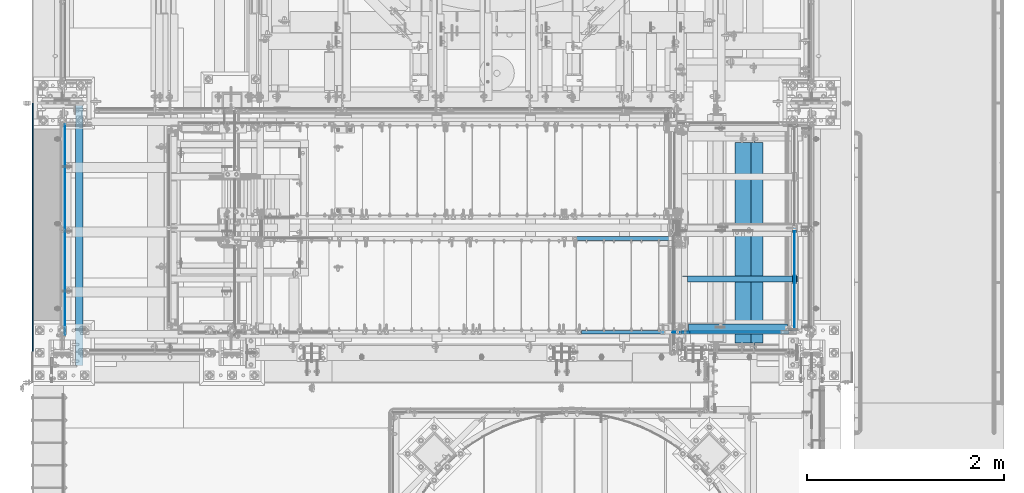
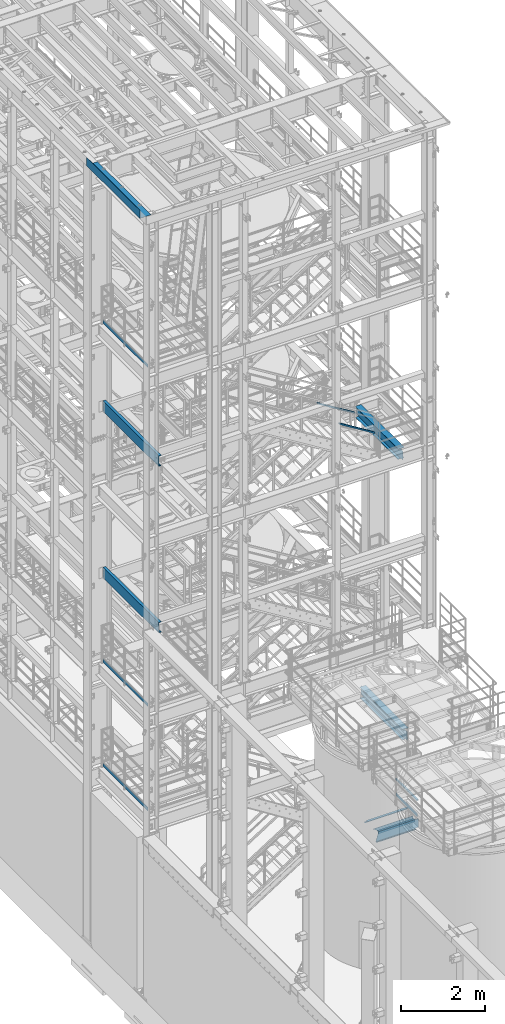
# One storey, part 951 of 1876: 14 beams, 2 members, 14 elements without a shape of their own.
"""IFC2X3 building model written with IfcOpenShell, lengths in millimetres."""

from ifc_helpers import new_model, si_unit, frame, origin_with_axes, place, context, subcontext, project, spatial, faceted_brep, material, type_object, element, aggregate, save


model = new_model("IFC2X3")

# Units and contexts
model_context = context("Model", 3, precision=1e-05, world=origin_with_axes())
body_context = subcontext(model_context, "Body", "Model", "MODEL_VIEW")
ifc_project = project(units=[si_unit("LENGTHUNIT", "METRE", prefix="MILLI"), si_unit("AREAUNIT", "SQUARE_METRE"), si_unit("VOLUMEUNIT", "CUBIC_METRE"), si_unit("MASSUNIT", "GRAM", prefix="KILO"), si_unit("TIMEUNIT", "SECOND"), si_unit("PLANEANGLEUNIT", "RADIAN"), si_unit("SOLIDANGLEUNIT", "STERADIAN"), si_unit("THERMODYNAMICTEMPERATUREUNIT", "DEGREE_CELSIUS"), si_unit("LUMINOUSINTENSITYUNIT", "LUMEN")], contexts=[model_context])

# Site, building, storey
site_placement = place(None, origin_with_axes())
site = spatial("IfcSite", under=ifc_project, at=site_placement, CompositionType="ELEMENT")
building_placement = place(site_placement, origin_with_axes())
building = spatial("IfcBuilding", under=site, at=building_placement, Name="Undefined", CompositionType="ELEMENT")
storey_placement = place(building_placement, origin_with_axes())
storey = spatial("IfcBuildingStorey", under=building, at=storey_placement, Name="Undefined", CompositionType="ELEMENT", Elevation=0.0)

# Assembly, beam
assembly_1_placement = place(storey_placement, origin_with_axes())
assembly_1 = element("IfcElementAssembly", 1, at=assembly_1_placement, inside=storey, Name="STRINGER", AssemblyPlace="NOTDEFINED", PredefinedType="RIGID_FRAME")
ifc_material_1 = material(Name="STEEL/A36")
beam_type_1 = type_object("IfcBeamType", Name="L2-1/2X2-1/2X1/4", PredefinedType="NOTDEFINED")
beam_1_placement = place(assembly_1_placement, frame((6299.20000038161, -6362.70000114059, 2266.27941853452), z_axis=(0.0, -1.0, 0.0), x_axis=(1.0, 0.0, 0.0)))
beam_1 = element("IfcBeam", 2, at=beam_1_placement, type_object=beam_type_1, material=ifc_material_1, Name="STRINGER", ObjectType="L2-1/2X2-1/2X1/4", context=body_context, shape_type="Brep", body=[
    faceted_brep([(1177.92499923677, 25.4000000000001, -25.3999999999996), (1177.92499923677, 25.4000000000001, 31.75), (58.737000000001, 25.4000000000001, 31.75), (58.737000000001, 25.4000000000001, -25.3999999999996), (1177.92499923677, 31.75, 31.75), (58.737000000001, 31.75, 31.75), (46.0370001907359, 6.34999909337057, -25.3999999999996), (46.0370001907359, 6.34999909337057, -31.75), (6.34999514770607, 6.34999909337057, -31.75), (6.34999514770607, 6.34999909337057, -25.3999999999996), (50.8970797087813, 7.31672901595857, -25.3999999999996), (50.8970797087813, 7.31672901595857, -31.75), (55.017256176935, 10.0697429164366, -25.3999999999996), (55.017256176935, 10.0697429164366, -31.75), (57.7702700774134, 14.1899193845902, -25.3999999999996), (57.7702700774134, 14.1899193845902, -31.75), (58.737000000001, 19.0499989026357, -25.3999999999996), (58.737000000001, 19.0499989026357, -31.75), (58.737000000001, 31.75, -31.75), (1177.92499923677, 31.75, -31.75), (1177.92499923677, -31.75, -25.3999999999996), (1177.92499923677, -31.75, -31.75), (6.34999999999854, -31.75, -25.3999999999996), (6.34999999999854, -31.75, -31.75), (6.34999514770607, -19.0499986178111, -31.75), (6.34999514770607, -19.0499986178111, -25.3999999999996)], [[[0, 1, 2, 3]], [[1, 4, 5, 2]], [[6, 7, 8, 9]], [[10, 11, 7, 6]], [[12, 13, 11, 10]], [[14, 15, 13, 12]], [[16, 17, 15, 14]], [[2, 5, 18, 17, 16, 3]], [[4, 19, 18, 5]], [[1, 0, 20, 21, 19, 4]], [[21, 20, 22, 23]], [[8, 7, 11, 13, 15, 17, 18, 19, 21, 23, 24]], [[9, 8, 24, 25]], [[20, 0, 3, 16, 14, 12, 10, 6, 9, 25, 22]], [[24, 23, 22, 25]]]),
])
aggregate(assembly_1, [beam_1])

assembly_2_placement = place(storey_placement, origin_with_axes())
assembly_2 = element("IfcElementAssembly", 3, at=assembly_2_placement, inside=storey, Name="STRINGER", AssemblyPlace="NOTDEFINED", PredefinedType="RIGID_FRAME")
beam_2_placement = place(assembly_2_placement, frame((7375.52499685318, -6851.65000035622, 2266.27941810345), z_axis=(0.0, 1.0, 0.0), x_axis=(-1.0, 0.0, 0.0)))
beam_2 = element("IfcBeam", 4, at=beam_2_placement, type_object=beam_type_1, material=ifc_material_1, Name="ANGLE", ObjectType="L2-1/2X2-1/2X1/4", context=body_context, shape_type="Brep", body=[
    faceted_brep([(0.0, 31.75, -31.75), (0.0, 31.75, 31.75), (1008.06249689888, 31.75, 31.7500000004475), (1008.06249683538, 31.75, -31.7499999995525), (0.0, 25.3999999999996, 31.75), (1008.06249689888, 25.4000000000001, 31.7500000004475), (0.0, 25.3999999999996, -25.3999999999996), (1008.06249684173, 25.4000000000001, -25.3999999995531), (0.0, -31.75, -25.3999999999996), (1008.06249684173, -31.75, -25.3999999995531), (0.0, -31.75, -31.75), (1008.06249683538, -31.75, -31.7499999995525)], [[[0, 1, 2, 3]], [[1, 4, 5, 2]], [[4, 6, 7, 5]], [[6, 8, 9, 7]], [[8, 10, 11, 9]], [[10, 0, 3, 11]], [[5, 7, 9, 11, 3, 2]], [[10, 8, 6, 4, 1, 0]]]),
])

assembly_3_placement = place(storey_placement, origin_with_axes())
assembly_3 = element("IfcElementAssembly", 5, at=assembly_3_placement, inside=storey, Name="RAIL", AssemblyPlace="NOTDEFINED", PredefinedType="RIGID_FRAME")
beam_type_2 = type_object("IfcBeamType", PredefinedType="NOTDEFINED")
beam_3_placement = place(assembly_3_placement, frame((27.3049999999948, -6925.945, 18049.875), z_axis=(0.0, 0.0, 1.0), x_axis=(0.0, 1.0, 0.0)))
beam_3 = element("IfcBeam", 6, at=beam_3_placement, type_object=beam_type_2, material=ifc_material_1, Name="PLATE", context=body_context, shape_type="Brep", body=[
    faceted_brep([(0.0, 3.17500000000018, -50.8000000000002), (0.0, 3.17500000000018, 50.8000000000002), (2137.7275, 3.175, 50.7999999999993), (2137.7275, 3.175, -50.7999999999993), (0.0, -3.17500000000018, 50.8000000000002), (2137.7275, -3.175, 50.7999999999993), (0.0, -3.17500000000018, -50.8000000000002), (2137.7275, -3.175, -50.7999999999993)], [[[0, 1, 2, 3]], [[1, 4, 5, 2]], [[4, 6, 7, 5]], [[6, 0, 3, 7]], [[5, 7, 3, 2]], [[6, 4, 1, 0]]]),
])
aggregate(assembly_3, [beam_3])

assembly_4_placement = place(storey_placement, origin_with_axes())
assembly_4 = element("IfcElementAssembly", 7, at=assembly_4_placement, inside=storey, Name="RAIL", AssemblyPlace="NOTDEFINED", PredefinedType="RIGID_FRAME")
beam_4_placement = place(assembly_4_placement, frame((27.3049999999948, -6925.945, 8220.075), z_axis=(0.0, 0.0, 1.0), x_axis=(0.0, 1.0, 0.0)))
beam_4 = element("IfcBeam", 8, at=beam_4_placement, type_object=beam_type_2, material=ifc_material_1, Name="PLATE", context=body_context, shape_type="Brep", body=[
    faceted_brep([(0.0, 3.17500000000018, -50.8000000000002), (0.0, 3.17500000000018, 50.8000000000002), (2137.7275, 3.175, 50.7999999999993), (2137.7275, 3.175, -50.7999999999993), (0.0, -3.17500000000018, 50.8000000000002), (2137.7275, -3.175, 50.7999999999993), (0.0, -3.17500000000018, -50.8000000000002), (2137.7275, -3.175, -50.7999999999993)], [[[0, 1, 2, 3]], [[1, 4, 5, 2]], [[4, 6, 7, 5]], [[6, 0, 3, 7]], [[5, 7, 3, 2]], [[6, 4, 1, 0]]]),
])
aggregate(assembly_4, [beam_4])

assembly_5_placement = place(storey_placement, origin_with_axes())
assembly_5 = element("IfcElementAssembly", 9, at=assembly_5_placement, inside=storey, Name="RAIL", AssemblyPlace="NOTDEFINED", PredefinedType="RIGID_FRAME")
beam_5_placement = place(assembly_5_placement, frame((27.3049999999947, -6925.945, 5197.475), z_axis=(0.0, 0.0, 1.0), x_axis=(0.0, 1.0, 0.0)))
beam_5 = element("IfcBeam", 10, at=beam_5_placement, type_object=beam_type_2, material=ifc_material_1, Name="PLATE", context=body_context, shape_type="Brep", body=[
    faceted_brep([(0.0, 3.17500000000018, -50.8000000000002), (0.0, 3.17500000000018, 50.8000000000002), (2137.7275, 3.175, 50.7999999999993), (2137.7275, 3.175, -50.7999999999993), (0.0, -3.17500000000018, 50.8000000000002), (2137.7275, -3.175, 50.7999999999993), (0.0, -3.17500000000018, -50.8000000000002), (2137.7275, -3.175, -50.7999999999993)], [[[0, 1, 2, 3]], [[1, 4, 5, 2]], [[4, 6, 7, 5]], [[6, 0, 3, 7]], [[5, 7, 3, 2]], [[6, 4, 1, 0]]]),
])
aggregate(assembly_5, [beam_5])

assembly_6_placement = place(storey_placement, origin_with_axes())
assembly_6 = element("IfcElementAssembly", 11, at=assembly_6_placement, inside=storey, Name="RAIL", AssemblyPlace="NOTDEFINED", PredefinedType="RIGID_FRAME")
beam_6_placement = place(assembly_6_placement, frame((7307.26250210862, -6902.45000037686, 2393.18362068965), z_axis=(0.0, 0.0, 1.0), x_axis=(-1.0, 0.0, 0.0)))
beam_6 = element("IfcBeam", 12, at=beam_6_placement, type_object=beam_type_2, material=ifc_material_1, Name="PLATE", context=body_context, shape_type="Brep", body=[
    faceted_brep([(0.0, 3.17500000000018, -50.8000000000002), (0.0, 3.17500000000018, 50.8000000000002), (1104.65422202064, 3.17500000000018, 50.8000000000002), (944.504006019978, 3.17500000000018, -50.8000000000002), (0.0, -3.17500000000018, 50.8000000000002), (1104.65422202064, -3.17500000000018, 50.8000000000002), (0.0, -3.17500000000018, -50.8000000000002), (944.504006019978, -3.17500000000018, -50.8000000000002)], [[[0, 1, 2, 3]], [[1, 4, 5, 2]], [[4, 6, 7, 5]], [[6, 0, 3, 7]], [[5, 7, 3, 2]], [[6, 4, 1, 0]]]),
])
aggregate(assembly_6, [beam_6])

# Assembly, beams
assembly_7_placement = place(storey_placement, origin_with_axes())
assembly_7 = element("IfcElementAssembly", 13, at=assembly_7_placement, inside=storey, Name="RAIL", AssemblyPlace="NOTDEFINED", PredefinedType="RIGID_FRAME")
beam_7_placement = place(assembly_7_placement, frame((7446.96249941626, -5861.05000117362, 2393.27941810157), z_axis=(0.0, 0.0, 1.0), x_axis=(0.0, -1.0, 0.0)))
beam_7 = element("IfcBeam", 14, at=beam_7_placement, type_object=beam_type_2, material=ifc_material_1, Name="PLATE", context=body_context, shape_type="Brep", body=[
    faceted_brep([(0.0, 3.17500000000018, -50.8000000000002), (0.0, 3.17500000000018, 50.8000000000002), (1022.35000148923, 3.17500000000018, 50.8000000000002), (1022.35000148923, 3.17500000000018, -50.8000000000002), (0.0, -3.17500000000018, 50.8000000000002), (1022.35000148923, -3.17500000000018, 50.8000000000002), (0.0, -3.17500000000018, -50.8000000000002), (1022.35000148923, -3.17500000000018, -50.8000000000002)], [[[0, 1, 2, 3]], [[1, 4, 5, 2]], [[4, 6, 7, 5]], [[6, 0, 3, 7]], [[5, 7, 3, 2]], [[6, 4, 1, 0]]]),
])
ifc_material_2 = material()
beam_type_3 = type_object("IfcBeamType", Name="HSS1-1/2X1-1/2X1/8", PredefinedType="NOTDEFINED")
beam_8_placement = place(assembly_7_placement, frame((7446.9625, -6902.45000113285, 2838.45), z_axis=(0.0, 0.0, 1.0), x_axis=(0.0, 1.0, 0.0)))
beam_8 = element("IfcBeam", 15, at=beam_8_placement, type_object=beam_type_3, material=ifc_material_2, Name="RAIL", ObjectType="HSS1-1/2X1-1/2X1/8", context=body_context, shape_type="Brep", body=[
    faceted_brep([(1041.40000072423, -19.0499992349996, 19.0499992350001), (1041.40000072423, -19.0499992349996, -19.0499992350001), (1041.40000072423, 19.0499992349996, -19.0499992350001), (1041.40000072423, 19.0499992349996, 19.0499992350001), (1041.40000072423, -15.8749992829999, 15.8749992829999), (1041.40000072423, 15.8749992829999, 15.8749992829999), (1041.40000072423, 15.8749992829999, -15.8749992829999), (1041.40000072423, -15.8749992829999, -15.8749992829999), (19.0500000000002, 19.0499992349996, 19.0499992350001), (19.0500000000002, -19.0499992349996, 19.0499992350001), (19.0500000000002, -19.0499992349996, -19.0499992350001), (19.0500000000002, 19.0499992349996, -19.0499992350001), (19.0500000000002, -15.8749992829999, 15.8749992829999), (19.0500000000002, -15.8749992829999, -15.8749992829999), (19.0500000000002, 15.8749992829999, -15.8749992829999), (19.0500000000002, 15.8749992829999, 15.8749992829999)], [[[0, 1, 2, 3], [4, 5, 6, 7]], [[0, 3, 8, 9]], [[2, 1, 10, 11]], [[1, 0, 9, 10]], [[3, 2, 11, 8]], [[9, 8, 11, 10], [12, 13, 14, 15]], [[4, 7, 13, 12]], [[7, 6, 14, 13]], [[6, 5, 15, 14]], [[5, 4, 12, 15]]]),
])
aggregate(assembly_7, [beam_8, beam_7])

# Assembly, member
assembly_8_placement = place(storey_placement, origin_with_axes())
assembly_8 = element("IfcElementAssembly", 16, at=assembly_8_placement, inside=storey, Name="RAIL", AssemblyPlace="NOTDEFINED", PredefinedType="RIGID_FRAME")
member_type = type_object("IfcMemberType", Name="HSS1-1/2X1-1/2X1/8", PredefinedType="NOTDEFINED")
member_1_placement = place(assembly_8_placement, frame((6273.80016411071, -6902.45000114791, 13915.4679585794), z_axis=(0.5266503718289, 0.0, 0.850081987723821), x_axis=(-0.850081987723821, 0.0, 0.5266503718289)))
member_1 = element("IfcMember", 17, at=member_1_placement, type_object=member_type, material=ifc_material_2, Name="RAIL", ObjectType="HSS1-1/2X1-1/2X1/8", context=body_context, shape_type="Brep", body=[
    faceted_brep([(1183.07747673049, -19.0499992349996, 19.0499992347723), (1159.47342600282, -19.0499992349996, -19.0499992352361), (1159.47342600282, 19.0499992349996, -19.0499992352361), (1183.07747673049, 19.0499992349996, 19.0499992347723), (1181.11047245393, -15.8749992829999, 15.8749992827725), (1181.11047245393, 15.8749992829999, 15.8749992827725), (1161.44043027938, 15.8749992829999, -15.8749992832345), (1161.44043027938, -15.8749992829999, -15.8749992832345), (34.2116285280431, 19.0499992349996, 19.0499992349996), (34.2116285280431, -19.0499992349996, 19.0499992349996), (10.6075778003737, -19.0499992349996, -19.0499992350105), (10.6075778003737, 19.0499992349996, -19.0499992350105), (32.2446242514848, -15.8749992829999, 15.874999282998), (12.5745344275801, -15.8749992829999, -15.8749992829962), (12.5745344275801, 15.8749992829999, -15.8749992829962), (32.2446242514848, 15.8749992829999, 15.874999282998)], [[[0, 1, 2, 3], [4, 5, 6, 7]], [[8, 9, 0, 3]], [[10, 11, 2, 1]], [[9, 10, 1, 0]], [[11, 8, 3, 2]], [[9, 8, 11, 10], [12, 13, 14, 15]], [[13, 12, 4, 7]], [[14, 13, 7, 6]], [[15, 14, 6, 5]], [[12, 15, 5, 4]]]),
])
aggregate(assembly_8, [member_1])

assembly_9_placement = place(storey_placement, origin_with_axes())
assembly_9 = element("IfcElementAssembly", 18, at=assembly_9_placement, inside=storey, Name="RAIL", AssemblyPlace="NOTDEFINED", PredefinedType="RIGID_FRAME")
member_2_placement = place(assembly_9_placement, frame((6273.80016366444, -5949.95000114554, 13915.4679588577), z_axis=(0.5266503718289, 0.0, 0.850081987723821), x_axis=(-0.850081987723821, 0.0, 0.5266503718289)))
member_2 = element("IfcMember", 19, at=member_2_placement, type_object=member_type, material=ifc_material_2, Name="RAIL", ObjectType="HSS1-1/2X1-1/2X1/8", context=body_context, shape_type="Brep", body=[
    faceted_brep([(1240.59545758478, -19.0499992349996, 19.0499992347577), (1216.99140685711, -19.0499992349996, -19.0499992352507), (1216.99140685711, 19.0499992349996, -19.0499992352507), (1240.59545758478, 19.0499992349996, 19.0499992347577), (1238.62845330822, -15.8749992829999, 15.8749992827579), (1238.62845330822, 15.8749992829999, 15.8749992827579), (1218.95841113367, 15.8749992829999, -15.8749992832491), (1218.95841113367, -15.8749992829999, -15.8749992832491), (34.2116285280431, 19.0499992349996, 19.0499992349996), (34.2116285280431, -19.0499992349996, 19.0499992349996), (10.6075778003737, -19.0499992349996, -19.0499992350105), (10.6075778003737, 19.0499992349996, -19.0499992350105), (32.2446242514848, -15.8749992829999, 15.874999282998), (12.5745344275801, -15.8749992829999, -15.8749992829962), (12.5745344275801, 15.8749992829999, -15.8749992829962), (32.2446242514848, 15.8749992829999, 15.874999282998)], [[[0, 1, 2, 3], [4, 5, 6, 7]], [[8, 9, 0, 3]], [[10, 11, 2, 1]], [[9, 10, 1, 0]], [[11, 8, 3, 2]], [[9, 8, 11, 10], [12, 13, 14, 15]], [[13, 12, 4, 7]], [[14, 13, 7, 6]], [[15, 14, 6, 5]], [[12, 15, 5, 4]]]),
])
aggregate(assembly_9, [member_2])

# Assembly, beam
assembly_10_placement = place(storey_placement, origin_with_axes())
assembly_10 = element("IfcElementAssembly", 20, at=assembly_10_placement, inside=storey, Name="STRINGER", AssemblyPlace="NOTDEFINED", PredefinedType="RIGID_FRAME")
beam_type_4 = type_object("IfcBeamType", Name="C12X20.7", PredefinedType="NOTDEFINED")
beam_9_placement = place(assembly_10_placement, frame((173.037499657747, -7242.17500114826, 15441.6124999981), z_axis=(0.0, 0.0, 1.0), x_axis=(0.0, 1.0, 0.0)))
beam_9 = element("IfcBeam", 21, at=beam_9_placement, type_object=beam_type_4, material=ifc_material_1, Name="STRINGER", ObjectType="C12X20.7", context=body_context, shape_type="Brep", body=[
    faceted_brep([(0.0, 38.1000000000004, -152.4), (0.0, 38.1000000000004, 152.4), (2645.5687500029, 38.1000000000004, 152.4), (2645.5687500029, 38.1000000000004, -152.4), (0.0, -38.1000000000004, 152.4), (2645.5687500029, -38.1000000000004, 152.4), (0.0, -38.1000000000004, 146.04746), (2645.5687500029, -38.1000000000004, 146.04746), (0.0, 30.1625000000004, 134.6749275), (2645.5687500029, 30.1625000000004, 134.6749275), (0.0, 30.1625000000004, -134.6749275), (2645.5687500029, 30.1625000000004, -134.6749275), (0.0, -38.1000000000004, -146.04746), (2645.5687500029, -38.1000000000004, -146.04746), (0.0, -38.1000000000004, -152.4), (2645.5687500029, -38.1000000000004, -152.4)], [[[0, 1, 2, 3]], [[1, 4, 5, 2]], [[4, 6, 7, 5]], [[6, 8, 9, 7]], [[8, 10, 11, 9]], [[10, 12, 13, 11]], [[12, 14, 15, 13]], [[14, 0, 3, 15]], [[5, 7, 9, 11, 13, 15, 3, 2]], [[14, 12, 10, 8, 6, 4, 1, 0]]]),
])
aggregate(assembly_10, [beam_9])

assembly_11_placement = place(storey_placement, origin_with_axes())
assembly_11 = element("IfcElementAssembly", 22, at=assembly_11_placement, inside=storey, Name="STRINGER", AssemblyPlace="NOTDEFINED", PredefinedType="RIGID_FRAME")
beam_10_placement = place(assembly_11_placement, frame((173.037499657747, -7242.17500114826, 10614.0249999981), z_axis=(0.0, 0.0, 1.0), x_axis=(0.0, 1.0, 0.0)))
beam_10 = element("IfcBeam", 23, at=beam_10_placement, type_object=beam_type_4, material=ifc_material_1, Name="STRINGER", ObjectType="C12X20.7", context=body_context, shape_type="Brep", body=[
    faceted_brep([(0.0, 38.1000000000004, -152.4), (0.0, 38.1000000000004, 152.4), (2645.5687500029, 38.1000000000004, 152.4), (2645.5687500029, 38.1000000000004, -152.4), (0.0, -38.1000000000004, 152.4), (2645.5687500029, -38.1000000000004, 152.4), (0.0, -38.1000000000004, 146.04746), (2645.5687500029, -38.1000000000004, 146.04746), (0.0, 30.1625000000004, 134.6749275), (2645.5687500029, 30.1625000000004, 134.6749275), (0.0, 30.1625000000004, -134.6749275), (2645.5687500029, 30.1625000000004, -134.6749275), (0.0, -38.1000000000004, -146.04746), (2645.5687500029, -38.1000000000004, -146.04746), (0.0, -38.1000000000004, -152.4), (2645.5687500029, -38.1000000000004, -152.4)], [[[0, 1, 2, 3]], [[1, 4, 5, 2]], [[4, 6, 7, 5]], [[6, 8, 9, 7]], [[8, 10, 11, 9]], [[10, 12, 13, 11]], [[12, 14, 15, 13]], [[14, 0, 3, 15]], [[5, 7, 9, 11, 13, 15, 3, 2]], [[14, 12, 10, 8, 6, 4, 1, 0]]]),
])
aggregate(assembly_11, [beam_10])

assembly_12_placement = place(storey_placement, origin_with_axes())
assembly_12 = element("IfcElementAssembly", 24, at=assembly_12_placement, inside=storey, Name="BENT PLATE", AssemblyPlace="NOTDEFINED", PredefinedType="RIGID_FRAME")
beam_type_5 = type_object("IfcBeamType", PredefinedType="NOTDEFINED")
beam_11_placement = place(assembly_12_placement, frame((2.28578142867657e-05, -5842.0, 22558.3750000001), z_axis=(0.0, 1.0, 0.0), x_axis=(-0.999999999968684, 0.0, -7.91400000071008e-06)))
beam_11 = element("IfcBeam", 25, at=beam_11_placement, type_object=beam_type_5, material=ifc_material_1, Name="BENT PLATE", context=body_context, shape_type="Brep", body=[
    faceted_brep([(-1.45519152283669e-11, -3.17499999999563, -1270.0), (-1.45519152283669e-11, -3.17499999999563, 1270.0), (1.36424205265939e-11, 3.17499999999563, 1270.0), (1.36424205265939e-11, 3.17499999999563, -1270.0), (298.449951180649, 3.17499990720171, 1270.0), (298.449951180649, 3.17499990720171, -1270.0), (304.799987775422, -3.17500009477953, -1270.0), (304.799987775422, -3.17500009477953, 1270.0), (298.448604036157, 236.934945778325, 1270.0), (298.448604036157, 236.934945778325, -1270.0), (304.798604036052, 236.934982372997, 1270.0), (304.798604036052, 236.934982372997, -1270.0)], [[[0, 1, 2, 3]], [[3, 2, 4, 5]], [[1, 0, 6, 7]], [[5, 4, 8, 9]], [[4, 2, 1, 7, 10, 8]], [[7, 6, 11, 10]], [[6, 0, 3, 5, 9, 11]], [[10, 11, 9, 8]]]),
])
aggregate(assembly_12, [beam_11])

# Beam
beam_type_6 = type_object("IfcBeamType", Name="MC12X10.6", PredefinedType="NOTDEFINED")
beam_12_placement = place(assembly_2_placement, frame((6382.77727308126, -6902.45000113286, 2177.28362069065), z_axis=(0.0, 0.0, 1.0), x_axis=(1.0, 0.0, 0.0)))
beam_12 = element("IfcBeam", 26, at=beam_12_placement, type_object=beam_type_6, material=ifc_material_1, Name="STRINGER", ObjectType="MC12X10.6", context=body_context, shape_type="Brep", body=[
    faceted_brep([(1005.44772691874, 14.2875000000004, -144.17817875), (1005.44772691874, -19.0500000000002, -144.841595), (1005.44772691874, -19.0500000000002, -152.4), (1005.44772691874, 19.0500000000002, -152.4), (1005.44772691874, 19.0500000000002, -139.699999809265), (1005.44772691874, 14.2875000000004, -139.699999809265), (1006.41445684133, 19.0500000000002, -134.83992029122), (1006.41445684133, 14.2875000000004, -134.83992029122), (1009.1674707418, 19.0500000000002, -130.719743823066), (1009.1674707418, 14.2875000000004, -130.719743823066), (1013.28764720996, 19.0500000000002, -127.966729922588), (1013.28764720996, 14.2875000000004, -127.966729922588), (1018.147726728, 19.0500000000002, -127.0), (1018.147726728, 14.2875000000004, -127.0), (1081.64772691874, 14.2875000000004, -127.0), (1081.64772691874, 19.0500000000002, -127.0), (-1.68647966347635e-06, -19.0500000000002, 152.400000000001), (-2.19529172653165, -19.0500000000002, 144.841595), (1005.44772691874, -19.0500000000002, 144.841595), (1005.44772691874, -19.0500000000002, 152.4), (-1.68647966347635e-06, 19.0500000000002, 152.400000000001), (1005.44772691874, 19.0500000000002, 152.4), (-88.5272648153214, -19.0500000000002, -152.4), (-86.3319730794719, -19.0500000000002, -144.841595), (-86.1392879546265, 14.2875000000004, -144.17817875), (-2.38797685137615, 14.2875000000004, 144.17817875), (-88.5272648153214, 19.0500000000002, -152.4), (1005.44772691874, 14.2875000000004, 144.17817875), (1005.44772691874, 14.2875000000004, 139.699999809265), (1005.44772691874, 19.0500000000002, 139.699999809265), (1006.41445684133, 14.2875000000004, 134.83992029122), (1006.41445684133, 19.0500000000002, 134.83992029122), (1009.1674707418, 14.2875000000004, 130.719743823066), (1009.1674707418, 19.0500000000002, 130.719743823066), (1013.28764720996, 14.2875000000004, 127.966729922588), (1013.28764720996, 19.0500000000002, 127.966729922588), (1018.147726728, 14.2875000000004, 127.0), (1018.147726728, 19.0500000000002, 127.0), (1081.64772691874, 14.2875000000004, 127.0), (1081.64772691874, 19.0500000000002, 127.0)], [[[0, 1, 2, 3, 4, 5]], [[5, 4, 6, 7]], [[7, 6, 8, 9]], [[9, 8, 10, 11]], [[11, 10, 12, 13]], [[14, 13, 12, 15]], [[16, 17, 18, 19]], [[20, 16, 19, 21]], [[22, 23, 24, 25, 17, 16, 20, 26]], [[17, 25, 27, 18]], [[19, 18, 27, 28, 29, 21]], [[30, 31, 29, 28]], [[32, 33, 31, 30]], [[34, 35, 33, 32]], [[36, 37, 35, 34]], [[38, 39, 37, 36]], [[39, 38, 14, 15]], [[10, 8, 6, 4, 3, 26, 20, 21, 29, 31, 33, 35, 37, 39, 15, 12]], [[22, 26, 3, 2]], [[23, 22, 2, 1]], [[24, 23, 1, 0]], [[38, 36, 34, 32, 30, 28, 27, 25, 24, 0, 5, 7, 9, 11, 13, 14]]]),
])

aggregate(assembly_2, [beam_12, beam_2])

# Assembly, beam
assembly_13_placement = place(storey_placement, origin_with_axes())
assembly_13 = element("IfcElementAssembly", 27, at=assembly_13_placement, inside=storey, Name="BEAM", AssemblyPlace="NOTDEFINED", PredefinedType="RIGID_FRAME")
ifc_material_3 = material(Name="STEEL/A992")
beam_type_7 = type_object("IfcBeamType", Name="W12X30", PredefinedType="NOTDEFINED")
beam_13_placement = place(assembly_13_placement, frame((6921.5, -7112.0, 13152.4375), z_axis=(0.0, 0.0, 1.0), x_axis=(0.0, 1.0, 0.0)))
beam_13 = element("IfcBeam", 28, at=beam_13_placement, type_object=beam_type_7, material=ifc_material_3, Name="BEAM", ObjectType="W12X30", context=body_context, shape_type="Brep", body=[
    faceted_brep([(2124.471875, -3.17500000000018, -146.049999999999), (2124.471875, -82.5500000000002, -146.049999999999), (2124.471875, -82.5500000000002, -157.1625), (2124.471875, 82.5500000000002, -157.1625), (2124.471875, 82.5500000000002, -146.049999999999), (2124.471875, 3.17500000000018, -146.049999999999), (2124.471875, 3.17500000000018, -138.112499809266), (2124.471875, -3.17500000000018, -138.112499809266), (2125.43860492259, 3.17500000000018, -133.252420291219), (2125.43860492259, -3.17500000000018, -133.252420291219), (2128.19161882306, 3.17500000000018, -129.132243823065), (2128.19161882306, -3.17500000000018, -129.132243823065), (2132.31179529122, 3.17500000000018, -126.379229922588), (2132.31179529122, -3.17500000000018, -126.379229922588), (2137.17187480926, 3.17500000000018, -125.4125), (2137.17187480926, -3.17500000000018, -125.4125), (2219.721875, -3.17500000000018, -125.4125), (2219.721875, 3.17500000000018, -125.4125), (100.012500000001, 3.17500000000018, 146.049999999999), (100.012500000001, 82.5500000000002, 146.049999999999), (2140.346875, 82.5500000000002, 146.049999999999), (2140.346875, 3.17500000000018, 146.049999999999), (112.712500000001, -3.17500000000018, -144.462499809266), (112.712500000001, 3.17500000000018, -144.462499809266), (112.712500000001, 3.17500000000018, -146.049999999999), (112.712500000001, 82.5500000000002, -146.049999999999), (112.712500000001, 82.5500000000002, -157.1625), (112.712500000001, -82.5500000000002, -157.1625), (112.712500000001, -82.5500000000002, -146.049999999999), (112.712500000001, -3.17500000000018, -146.049999999999), (111.745770077413, -3.17500000000018, -139.602420291219), (111.745770077413, 3.17500000000018, -139.602420291219), (108.992756176935, -3.17500000000018, -135.482243823066), (108.992756176935, 3.17500000000018, -135.482243823066), (104.872579708781, -3.17500000000018, -132.729229922588), (104.872579708781, 3.17500000000018, -132.729229922588), (100.012500190735, -3.17500000000018, -131.762500000001), (100.012500190735, 3.17500000000018, -131.762500000001), (17.4624999999996, -3.17500000000018, -131.762500000004), (17.4624999999996, 3.17500000000018, -131.762500000004), (17.4624999999996, -3.17500000000018, 119.0625), (17.4624999999996, 3.17500000000018, 119.0625), (87.3125001907356, -3.17500000000018, 119.0625), (87.3125001907356, 3.17500000000018, 119.0625), (92.1725797087811, -3.17500000000018, 120.029229922588), (92.1725797087811, 3.17500000000018, 120.029229922588), (96.2927561769347, -3.17500000000018, 122.782243823065), (96.2927561769347, 3.17500000000018, 122.782243823065), (99.0457700774132, -3.17500000000018, 126.902420291219), (99.0457700774132, 3.17500000000018, 126.902420291219), (100.012500000001, -3.17500000000018, 131.762499809265), (100.012500000001, 3.17500000000018, 131.762499809265), (100.012500000001, -82.5500000000002, 157.1625), (100.012500000001, 82.5500000000002, 157.1625), (100.012500000001, -3.17500000000018, 146.049999999999), (100.012500000001, -82.5500000000002, 146.049999999999), (2140.346875, -3.17500000000018, 146.049999999999), (2140.346875, -82.5500000000002, 146.049999999999), (2140.346875, -82.5500000000002, 157.1625), (2140.346875, 82.5500000000002, 157.1625), (2140.346875, -3.17500000000018, 138.112499809266), (2140.346875, 3.17500000000018, 138.112499809266), (2141.31360492259, -3.17500000000018, 133.252420291219), (2141.31360492259, 3.17500000000018, 133.252420291219), (2144.06661882306, -3.17500000000018, 129.132243823065), (2144.06661882306, 3.17500000000018, 129.132243823065), (2148.18679529122, -3.17500000000018, 126.379229922588), (2148.18679529122, 3.17500000000018, 126.379229922588), (2153.04687480926, -3.17500000000018, 125.4125), (2153.04687480926, 3.17500000000018, 125.4125), (2219.721875, -3.17500000000018, 125.4125), (2219.721875, 3.17500000000018, 125.4125)], [[[0, 1, 2, 3, 4, 5, 6, 7]], [[7, 6, 8, 9]], [[9, 8, 10, 11]], [[11, 10, 12, 13]], [[13, 12, 14, 15]], [[16, 15, 14, 17]], [[18, 19, 20, 21]], [[22, 23, 24, 25, 26, 27, 28, 29]], [[30, 31, 23, 22]], [[32, 33, 31, 30]], [[34, 35, 33, 32]], [[36, 37, 35, 34]], [[38, 39, 37, 36]], [[40, 41, 39, 38]], [[42, 43, 41, 40]], [[44, 45, 43, 42]], [[46, 47, 45, 44]], [[48, 49, 47, 46]], [[50, 51, 49, 48]], [[52, 53, 19, 18, 51, 50, 54, 55]], [[55, 54, 56, 57]], [[52, 55, 57, 58]], [[53, 52, 58, 59]], [[19, 53, 59, 20]], [[58, 57, 56, 60, 61, 21, 20, 59]], [[62, 63, 61, 60]], [[64, 65, 63, 62]], [[66, 67, 65, 64]], [[68, 69, 67, 66]], [[70, 71, 69, 68]], [[71, 70, 16, 17]], [[12, 10, 8, 6, 5, 24, 23, 31, 33, 35, 37, 39, 41, 43, 45, 47, 49, 51, 18, 21, 61, 63, 65, 67, 69, 71, 17, 14]], [[25, 24, 5, 4]], [[26, 25, 4, 3]], [[27, 26, 3, 2]], [[28, 27, 2, 1]], [[29, 28, 1, 0]], [[70, 68, 66, 64, 62, 60, 56, 54, 50, 48, 46, 44, 42, 40, 38, 36, 34, 32, 30, 22, 29, 0, 7, 9, 11, 13, 15, 16]]]),
])
aggregate(assembly_13, [beam_13])

assembly_14_placement = place(storey_placement, origin_with_axes())
assembly_14 = element("IfcElementAssembly", 29, at=assembly_14_placement, inside=storey, Name="BEAM", AssemblyPlace="NOTDEFINED", PredefinedType="RIGID_FRAME")
beam_14_placement = place(assembly_14_placement, frame((7042.15, -7112.0, 4973.6375), z_axis=(0.0, 0.0, 1.0), x_axis=(0.0, 1.0, 0.0)))
beam_14 = element("IfcBeam", 30, at=beam_14_placement, type_object=beam_type_7, material=ifc_material_3, Name="BEAM", ObjectType="W12X30", context=body_context, shape_type="Brep", body=[
    faceted_brep([(2124.075, -3.17500000000018, -146.05), (2124.075, -82.5500000000002, -146.05), (2124.075, -82.5500000000002, -157.1625), (2124.075, 82.5500000000002, -157.1625), (2124.075, 82.5500000000002, -146.05), (2124.075, 3.17500000000018, -146.05), (2124.075, 3.17500000000018, -144.462499809264), (2124.075, -3.17500000000018, -144.462499809264), (2125.04172992259, 3.17500000000018, -139.602420291219), (2125.04172992259, -3.17500000000018, -139.602420291219), (2127.79474382307, 3.17500000000018, -135.482243823065), (2127.79474382307, -3.17500000000018, -135.482243823065), (2131.91492029122, 3.17500000000018, -132.729229922586), (2131.91492029122, -3.17500000000018, -132.729229922586), (2136.77499980927, 3.17500000000018, -131.762499999999), (2136.77499980927, -3.17500000000018, -131.762499999999), (2219.325, -3.17500000000018, -131.762499999999), (2219.325, 3.17500000000018, -131.762499999999), (100.012500000001, 3.17500000000018, 146.049999999999), (100.012500000001, 82.5500000000002, 146.049999999999), (2139.95, 82.5500000000002, 146.05), (2139.95, 3.17500000000018, 146.05), (112.712500000001, -3.17500000000018, -144.462499809266), (112.712500000001, 3.17500000000018, -144.462499809266), (112.712500000001, 3.17500000000018, -146.049999999999), (112.712500000001, 82.5500000000002, -146.049999999999), (112.712500000001, 82.5500000000002, -157.1625), (112.712500000001, -82.5500000000002, -157.1625), (112.712500000001, -82.5500000000002, -146.049999999999), (112.712500000001, -3.17500000000018, -146.049999999999), (111.745770077413, -3.17500000000018, -139.602420291219), (111.745770077413, 3.17500000000018, -139.602420291219), (108.992756176935, -3.17500000000018, -135.482243823066), (108.992756176935, 3.17500000000018, -135.482243823066), (104.872579708781, -3.17500000000018, -132.729229922588), (104.872579708781, 3.17500000000018, -132.729229922588), (100.012500190735, -3.17500000000018, -131.762500000001), (100.012500190735, 3.17500000000018, -131.762500000001), (17.4624999999996, -3.17500000000018, -131.762500000004), (17.4624999999996, 3.17500000000018, -131.762500000004), (17.4624999999996, -3.17500000000018, 119.0625), (17.4624999999996, 3.17500000000018, 119.0625), (87.3125001907356, -3.17500000000018, 119.0625), (87.3125001907356, 3.17500000000018, 119.0625), (92.1725797087811, -3.17500000000018, 120.029229922588), (92.1725797087811, 3.17500000000018, 120.029229922588), (96.2927561769347, -3.17500000000018, 122.782243823065), (96.2927561769347, 3.17500000000018, 122.782243823065), (99.0457700774132, -3.17500000000018, 126.902420291219), (99.0457700774132, 3.17500000000018, 126.902420291219), (100.012500000001, -3.17500000000018, 131.762499809265), (100.012500000001, 3.17500000000018, 131.762499809265), (100.012500000001, -82.5500000000002, 157.1625), (100.012500000001, 82.5500000000002, 157.1625), (100.012500000001, -3.17500000000018, 146.049999999999), (100.012500000001, -82.5500000000002, 146.049999999999), (2139.95, -3.17500000000018, 146.05), (2139.95, -82.5500000000002, 146.05), (2139.95, -82.5500000000002, 157.1625), (2139.95, 82.5500000000002, 157.1625), (2139.95, -3.17500000000018, 144.462499809266), (2139.95, 3.17500000000018, 144.462499809266), (2140.91672992259, -3.17500000000018, 139.60242029122), (2140.91672992259, 3.17500000000018, 139.60242029122), (2143.66974382307, -3.17500000000018, 135.482243823067), (2143.66974382307, 3.17500000000018, 135.482243823067), (2147.78992029122, -3.17500000000018, 132.729229922588), (2147.78992029122, 3.17500000000018, 132.729229922588), (2152.64999980927, -3.17500000000018, 131.762500000001), (2152.64999980927, 3.17500000000018, 131.762500000001), (2219.325, -3.17500000000018, 131.762500000001), (2219.325, 3.17500000000018, 131.762500000001)], [[[0, 1, 2, 3, 4, 5, 6, 7]], [[7, 6, 8, 9]], [[9, 8, 10, 11]], [[11, 10, 12, 13]], [[13, 12, 14, 15]], [[16, 15, 14, 17]], [[18, 19, 20, 21]], [[22, 23, 24, 25, 26, 27, 28, 29]], [[30, 31, 23, 22]], [[32, 33, 31, 30]], [[34, 35, 33, 32]], [[36, 37, 35, 34]], [[38, 39, 37, 36]], [[40, 41, 39, 38]], [[42, 43, 41, 40]], [[44, 45, 43, 42]], [[46, 47, 45, 44]], [[48, 49, 47, 46]], [[50, 51, 49, 48]], [[52, 53, 19, 18, 51, 50, 54, 55]], [[55, 54, 56, 57]], [[52, 55, 57, 58]], [[53, 52, 58, 59]], [[19, 53, 59, 20]], [[58, 57, 56, 60, 61, 21, 20, 59]], [[62, 63, 61, 60]], [[64, 65, 63, 62]], [[66, 67, 65, 64]], [[68, 69, 67, 66]], [[70, 71, 69, 68]], [[71, 70, 16, 17]], [[12, 10, 8, 6, 5, 24, 23, 31, 33, 35, 37, 39, 41, 43, 45, 47, 49, 51, 18, 21, 61, 63, 65, 67, 69, 71, 17, 14]], [[25, 24, 5, 4]], [[26, 25, 4, 3]], [[27, 26, 3, 2]], [[28, 27, 2, 1]], [[29, 28, 1, 0]], [[70, 68, 66, 64, 62, 60, 56, 54, 50, 48, 46, 44, 42, 40, 38, 36, 34, 32, 30, 22, 29, 0, 7, 9, 11, 13, 15, 16]]]),
])
aggregate(assembly_14, [beam_14])

save(model, "model.ifc")
